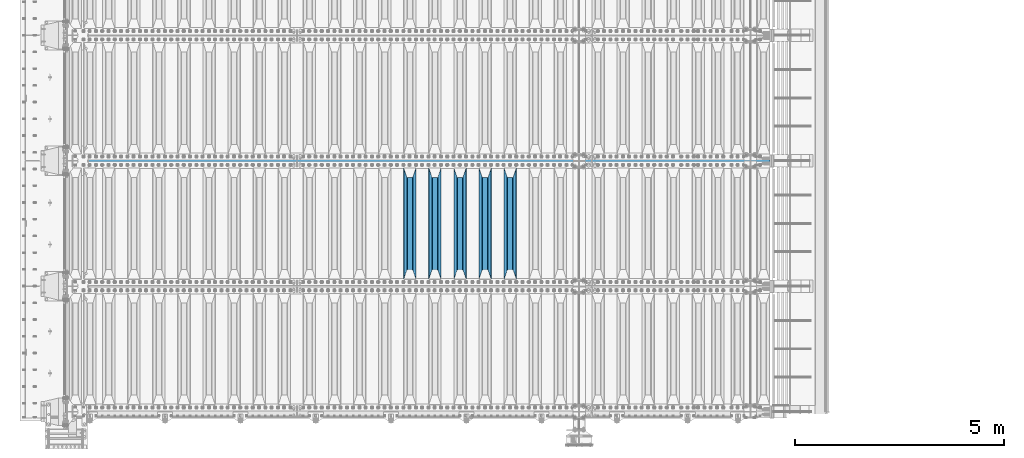
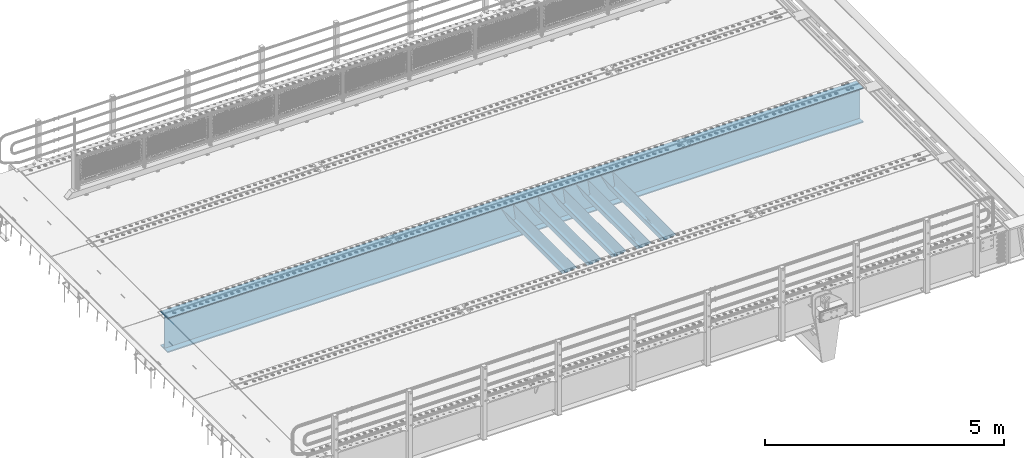
# One storey, part 111 of 257: 6 beams.
"""IFC2X3 building model written with IfcOpenShell, lengths in millimetres."""

from ifc_helpers import new_model, si_unit, frame, origin_with_axes, place, context, subcontext, project, spatial, faceted_brep, material, type_object, element, save


model = new_model("IFC2X3")

# Units and contexts
model_context = context("Model", 3, precision=1e-05, world=origin_with_axes())
body_context = subcontext(model_context, "Body", "Model", "MODEL_VIEW")
ifc_project = project(units=[si_unit("LENGTHUNIT", "METRE", prefix="MILLI"), si_unit("AREAUNIT", "SQUARE_METRE"), si_unit("VOLUMEUNIT", "CUBIC_METRE"), si_unit("MASSUNIT", "GRAM", prefix="KILO"), si_unit("TIMEUNIT", "SECOND"), si_unit("PLANEANGLEUNIT", "RADIAN"), si_unit("SOLIDANGLEUNIT", "STERADIAN"), si_unit("THERMODYNAMICTEMPERATUREUNIT", "DEGREE_CELSIUS"), si_unit("LUMINOUSINTENSITYUNIT", "LUMEN")], contexts=[model_context])

# Site, building, storey
site_placement = place(None, origin_with_axes())
site = spatial("IfcSite", under=ifc_project, at=site_placement, CompositionType="ELEMENT")
building_placement = place(site_placement, origin_with_axes())
building = spatial("IfcBuilding", under=site, at=building_placement, Name="Standard", CompositionType="ELEMENT")
storey_placement = place(building_placement, origin_with_axes())
storey = spatial("IfcBuildingStorey", under=building, at=storey_placement, Name="Undefined", CompositionType="ELEMENT", Elevation=0.0)

# Beams
ifc_material = material(Name="STEEL/S355N")
beam_type_1 = type_object("IfcBeamType", PredefinedType="NOTDEFINED")
beam_1_placement = place(storey_placement, frame((53050.0, 3175.0, -115.0), z_axis=(0.0, 0.0, 1.0), x_axis=(0.0, 1.0, 0.0)))
element("IfcBeam", 1, at=beam_1_placement, inside=storey, type_object=beam_type_1, material=ifc_material, context=body_context, shape_type="Brep", body=[
    faceted_brep([(0.0, 150.0, 115.0), (0.0, 143.690000000002, 115.0), (2650.00000000297, 143.690000000002, 115.0), (2650.00000000297, 150.0, 115.0), (2650.00000000297, 142.059565218406, 110.0000000031), (2650.00000000297, 148.369565218403, 110.0000000031), (2441.90079219208, -80.1103600731149, -98.0992078077845), (2437.7588105432, -77.5672621345584, -102.241189456673), (2434.06523489746, -74.4080125315522, -105.934765102404), (2430.91086095089, -70.7102721255724, -109.089139048974), (2428.37322971128, -66.5649389910031, -111.626770288588), (2426.51472138055, -62.0739139532889, -113.485278619323), (2425.38102192091, -57.3475956567636, -114.618978078955), (2424.99999999987, -52.5021667386536, -115.0), (2424.99999999987, 52.5021667386536, -115.0), (2425.38102192091, 57.3475956567636, -114.618978078955), (2426.51472138055, 62.0739139532889, -113.485278619323), (2428.37322971128, 66.5649389910031, -111.626770288588), (2430.91086095089, 70.7102721255724, -109.089139048974), (2434.06523489746, 74.4080125315522, -105.934765102404), (2437.7588105432, 77.5672621345584, -102.241189456673), (2441.90079219208, 80.1103600731149, -98.0992078077846), (2446.38936140511, 81.9747917625791, -93.6106385947584), (2448.24948500409, 76.2713538057287, -91.7505149957729), (2444.62967112262, 74.76777986261, -95.3703288772456), (2441.28936334126, 72.7168944282894, -98.710636658607), (2438.31067330438, 70.1691124903809, -101.689326695487), (2435.76682334747, 67.1870637758839, -104.233176652398), (2433.72034654133, 63.8440531834931, -106.279653458539), (2432.22154950041, 60.2222587982324, -107.778450499454), (2431.30727574265, 56.4107117849126, -108.692724257221), (2430.99999999987, 52.5031078186876, -109.0), (2430.99999999987, -52.5031078186876, -109.0), (2431.30727574265, -56.4107117849126, -108.692724257221), (2432.22154950041, -60.2222587982324, -107.778450499454), (2433.72034654133, -63.8440531834931, -106.279653458539), (2435.76682334747, -67.1870637758839, -104.233176652398), (2438.31067330438, -70.1691124903809, -101.689326695487), (2441.28936334126, -72.7168944282894, -98.7106366586071), (2444.62967112262, -74.76777986261, -95.3703288772457), (2448.24948500409, -76.2713538057287, -91.7505149957729), (2650.00000000297, -142.059565218406, 110.0000000031), (2650.00000000297, -148.369565218403, 110.0000000031), (2446.38936140511, -81.9747917625791, -93.6106385947584), (2650.00000000297, -143.690000000002, 115.0), (2650.00000000297, -150.0, 115.0), (0.0, -143.690000000002, 115.0), (0.0, -150.0, 115.0), (0.0, -148.369565218258, 110.000000002662), (203.61063859742, -81.9747917625791, -93.6106385947584), (208.099207810447, -80.1103600731149, -98.0992078077845), (212.241189459335, -77.5672621345584, -102.241189456673), (215.934765105066, -74.4080125315522, -105.934765102404), (219.089139051636, -70.7102721255724, -109.089139048974), (221.626770291251, -66.5649389910031, -111.626770288588), (223.485278621985, -62.0739139532889, -113.485278619323), (224.618978081617, -57.3475956567636, -114.618978078955), (225.000000002662, -52.5021667386536, -115.0), (225.000000002662, 52.5021667386536, -115.0), (224.618978081617, 57.3475956567636, -114.618978078955), (223.485278621985, 62.0739139532889, -113.485278619323), (221.626770291251, 66.5649389910031, -111.626770288588), (219.089139051636, 70.7102721255724, -109.089139048974), (215.934765105066, 74.4080125315522, -105.934765102404), (212.241189459335, 77.5672621345584, -102.241189456673), (208.099207810447, 80.1103600731149, -98.0992078077846), (203.61063859742, 81.9747917625791, -93.6106385947584), (0.0, 148.369565218258, 110.000000002662), (0.0, 142.05956521826, 110.000000002662), (201.750514998435, 76.2713538057287, -91.7505149957729), (205.370328879908, 74.76777986261, -95.3703288772456), (208.710636661269, 72.7168944282894, -98.710636658607), (211.689326698149, 70.1691124903809, -101.689326695487), (214.233176655061, 67.1870637758839, -104.233176652398), (216.279653461201, 63.8440531834931, -106.279653458539), (217.778450502116, 60.2222587982324, -107.778450499454), (218.692724259884, 56.4107117849126, -108.692724257221), (219.000000002662, 52.5031078186876, -109.0), (219.000000002662, -52.5031078186876, -109.0), (218.692724259884, -56.4107117849126, -108.692724257221), (217.778450502116, -60.2222587982324, -107.778450499454), (216.279653461201, -63.8440531834931, -106.279653458539), (214.233176655061, -67.1870637758839, -104.233176652398), (211.689326698149, -70.1691124903809, -101.689326695487), (208.710636661269, -72.7168944282894, -98.7106366586071), (205.370328879908, -74.76777986261, -95.3703288772457), (201.750514998435, -76.2713538057287, -91.7505149957729), (0.0, -142.05956521826, 110.000000002662)], [[[0, 1, 2, 3]], [[3, 2, 4, 5]], [[6, 7, 8, 9, 10, 11, 12, 13, 14, 15, 16, 17, 18, 19, 20, 21, 22, 5, 4, 23, 24, 25, 26, 27, 28, 29, 30, 31, 32, 33, 34, 35, 36, 37, 38, 39, 40, 41, 42, 43]], [[44, 45, 42, 41]], [[46, 47, 45, 44]], [[43, 42, 45, 47, 48, 49]], [[6, 43, 49, 50]], [[7, 6, 50, 51]], [[8, 7, 51, 52]], [[9, 8, 52, 53]], [[10, 9, 53, 54]], [[11, 10, 54, 55]], [[12, 11, 55, 56]], [[13, 12, 56, 57]], [[14, 13, 57, 58]], [[15, 14, 58, 59]], [[16, 15, 59, 60]], [[17, 16, 60, 61]], [[18, 17, 61, 62]], [[19, 18, 62, 63]], [[20, 19, 63, 64]], [[21, 20, 64, 65]], [[22, 21, 65, 66]], [[0, 3, 5, 22, 66, 67]], [[1, 0, 67, 68]], [[23, 4, 2, 1, 68, 69]], [[24, 23, 69, 70]], [[25, 24, 70, 71]], [[26, 25, 71, 72]], [[27, 26, 72, 73]], [[28, 27, 73, 74]], [[29, 28, 74, 75]], [[30, 29, 75, 76]], [[31, 30, 76, 77]], [[32, 31, 77, 78]], [[33, 32, 78, 79]], [[34, 33, 79, 80]], [[35, 34, 80, 81]], [[36, 35, 81, 82]], [[37, 36, 82, 83]], [[38, 37, 83, 84]], [[39, 38, 84, 85]], [[40, 39, 85, 86]], [[46, 44, 41, 40, 86, 87]], [[47, 46, 87, 48]], [[86, 85, 84, 83, 82, 81, 80, 79, 78, 77, 76, 75, 74, 73, 72, 71, 70, 69, 68, 67, 66, 65, 64, 63, 62, 61, 60, 59, 58, 57, 56, 55, 54, 53, 52, 51, 50, 49, 48, 87]]]),
])
beam_2_placement = place(storey_placement, frame((52450.0, 3175.0, -115.0), z_axis=(0.0, 0.0, 1.0), x_axis=(0.0, 1.0, 0.0)))
element("IfcBeam", 2, at=beam_2_placement, inside=storey, type_object=beam_type_1, material=ifc_material, context=body_context, shape_type="Brep", body=[
    faceted_brep([(0.0, 150.0, 115.0), (0.0, 143.690000000002, 115.0), (2650.00000000297, 143.690000000002, 115.0), (2650.00000000297, 150.0, 115.0), (2650.00000000297, 142.059565218406, 110.0000000031), (2650.00000000297, 148.369565218403, 110.0000000031), (2441.90079219208, -80.1103600731149, -98.0992078077845), (2437.7588105432, -77.5672621345584, -102.241189456673), (2434.06523489746, -74.4080125315522, -105.934765102404), (2430.91086095089, -70.7102721255724, -109.089139048974), (2428.37322971128, -66.5649389910031, -111.626770288588), (2426.51472138055, -62.0739139532889, -113.485278619323), (2425.38102192091, -57.3475956567636, -114.618978078955), (2424.99999999987, -52.5021667386536, -115.0), (2424.99999999987, 52.5021667386536, -115.0), (2425.38102192091, 57.3475956567636, -114.618978078955), (2426.51472138055, 62.0739139532889, -113.485278619323), (2428.37322971128, 66.5649389910031, -111.626770288588), (2430.91086095089, 70.7102721255724, -109.089139048974), (2434.06523489746, 74.4080125315522, -105.934765102404), (2437.7588105432, 77.5672621345584, -102.241189456673), (2441.90079219208, 80.1103600731149, -98.0992078077846), (2446.38936140511, 81.9747917625791, -93.6106385947584), (2448.24948500409, 76.2713538057287, -91.7505149957729), (2444.62967112262, 74.76777986261, -95.3703288772456), (2441.28936334126, 72.7168944282894, -98.710636658607), (2438.31067330438, 70.1691124903809, -101.689326695487), (2435.76682334747, 67.1870637758839, -104.233176652398), (2433.72034654133, 63.8440531834931, -106.279653458539), (2432.22154950041, 60.2222587982324, -107.778450499454), (2431.30727574265, 56.4107117849126, -108.692724257221), (2430.99999999987, 52.5031078186876, -109.0), (2430.99999999987, -52.5031078186876, -109.0), (2431.30727574265, -56.4107117849126, -108.692724257221), (2432.22154950041, -60.2222587982324, -107.778450499454), (2433.72034654133, -63.8440531834931, -106.279653458539), (2435.76682334747, -67.1870637758839, -104.233176652398), (2438.31067330438, -70.1691124903809, -101.689326695487), (2441.28936334126, -72.7168944282894, -98.7106366586071), (2444.62967112262, -74.76777986261, -95.3703288772457), (2448.24948500409, -76.2713538057287, -91.7505149957729), (2650.00000000297, -142.059565218406, 110.0000000031), (2650.00000000297, -148.369565218403, 110.0000000031), (2446.38936140511, -81.9747917625791, -93.6106385947584), (2650.00000000297, -143.690000000002, 115.0), (2650.00000000297, -150.0, 115.0), (0.0, -143.690000000002, 115.0), (0.0, -150.0, 115.0), (0.0, -148.369565218258, 110.000000002662), (203.61063859742, -81.9747917625791, -93.6106385947584), (208.099207810447, -80.1103600731149, -98.0992078077845), (212.241189459335, -77.5672621345584, -102.241189456673), (215.934765105066, -74.4080125315522, -105.934765102404), (219.089139051636, -70.7102721255724, -109.089139048974), (221.626770291251, -66.5649389910031, -111.626770288588), (223.485278621985, -62.0739139532889, -113.485278619323), (224.618978081617, -57.3475956567636, -114.618978078955), (225.000000002662, -52.5021667386536, -115.0), (225.000000002662, 52.5021667386536, -115.0), (224.618978081617, 57.3475956567636, -114.618978078955), (223.485278621985, 62.0739139532889, -113.485278619323), (221.626770291251, 66.5649389910031, -111.626770288588), (219.089139051636, 70.7102721255724, -109.089139048974), (215.934765105066, 74.4080125315522, -105.934765102404), (212.241189459335, 77.5672621345584, -102.241189456673), (208.099207810447, 80.1103600731149, -98.0992078077846), (203.61063859742, 81.9747917625791, -93.6106385947584), (0.0, 148.369565218258, 110.000000002662), (0.0, 142.05956521826, 110.000000002662), (201.750514998435, 76.2713538057287, -91.7505149957729), (205.370328879908, 74.76777986261, -95.3703288772456), (208.710636661269, 72.7168944282894, -98.710636658607), (211.689326698149, 70.1691124903809, -101.689326695487), (214.233176655061, 67.1870637758839, -104.233176652398), (216.279653461201, 63.8440531834931, -106.279653458539), (217.778450502116, 60.2222587982324, -107.778450499454), (218.692724259884, 56.4107117849126, -108.692724257221), (219.000000002662, 52.5031078186876, -109.0), (219.000000002662, -52.5031078186876, -109.0), (218.692724259884, -56.4107117849126, -108.692724257221), (217.778450502116, -60.2222587982324, -107.778450499454), (216.279653461201, -63.8440531834931, -106.279653458539), (214.233176655061, -67.1870637758839, -104.233176652398), (211.689326698149, -70.1691124903809, -101.689326695487), (208.710636661269, -72.7168944282894, -98.7106366586071), (205.370328879908, -74.76777986261, -95.3703288772457), (201.750514998435, -76.2713538057287, -91.7505149957729), (0.0, -142.05956521826, 110.000000002662)], [[[0, 1, 2, 3]], [[3, 2, 4, 5]], [[6, 7, 8, 9, 10, 11, 12, 13, 14, 15, 16, 17, 18, 19, 20, 21, 22, 5, 4, 23, 24, 25, 26, 27, 28, 29, 30, 31, 32, 33, 34, 35, 36, 37, 38, 39, 40, 41, 42, 43]], [[44, 45, 42, 41]], [[46, 47, 45, 44]], [[43, 42, 45, 47, 48, 49]], [[6, 43, 49, 50]], [[7, 6, 50, 51]], [[8, 7, 51, 52]], [[9, 8, 52, 53]], [[10, 9, 53, 54]], [[11, 10, 54, 55]], [[12, 11, 55, 56]], [[13, 12, 56, 57]], [[14, 13, 57, 58]], [[15, 14, 58, 59]], [[16, 15, 59, 60]], [[17, 16, 60, 61]], [[18, 17, 61, 62]], [[19, 18, 62, 63]], [[20, 19, 63, 64]], [[21, 20, 64, 65]], [[22, 21, 65, 66]], [[0, 3, 5, 22, 66, 67]], [[1, 0, 67, 68]], [[23, 4, 2, 1, 68, 69]], [[24, 23, 69, 70]], [[25, 24, 70, 71]], [[26, 25, 71, 72]], [[27, 26, 72, 73]], [[28, 27, 73, 74]], [[29, 28, 74, 75]], [[30, 29, 75, 76]], [[31, 30, 76, 77]], [[32, 31, 77, 78]], [[33, 32, 78, 79]], [[34, 33, 79, 80]], [[35, 34, 80, 81]], [[36, 35, 81, 82]], [[37, 36, 82, 83]], [[38, 37, 83, 84]], [[39, 38, 84, 85]], [[40, 39, 85, 86]], [[46, 44, 41, 40, 86, 87]], [[47, 46, 87, 48]], [[86, 85, 84, 83, 82, 81, 80, 79, 78, 77, 76, 75, 74, 73, 72, 71, 70, 69, 68, 67, 66, 65, 64, 63, 62, 61, 60, 59, 58, 57, 56, 55, 54, 53, 52, 51, 50, 49, 48, 87]]]),
])
beam_3_placement = place(storey_placement, frame((51850.0, 3175.0, -115.0), z_axis=(0.0, 0.0, 1.0), x_axis=(0.0, 1.0, 0.0)))
element("IfcBeam", 3, at=beam_3_placement, inside=storey, type_object=beam_type_1, material=ifc_material, context=body_context, shape_type="Brep", body=[
    faceted_brep([(0.0, 150.0, 115.0), (0.0, 143.690000000002, 115.0), (2650.00000000297, 143.690000000002, 115.0), (2650.00000000297, 150.0, 115.0), (2650.00000000297, 142.059565218406, 110.0000000031), (2650.00000000297, 148.369565218403, 110.0000000031), (2441.90079219208, -80.1103600731149, -98.0992078077845), (2437.7588105432, -77.5672621345584, -102.241189456673), (2434.06523489746, -74.4080125315522, -105.934765102404), (2430.91086095089, -70.7102721255724, -109.089139048974), (2428.37322971128, -66.5649389910031, -111.626770288588), (2426.51472138055, -62.0739139532889, -113.485278619323), (2425.38102192091, -57.3475956567636, -114.618978078955), (2424.99999999987, -52.5021667386536, -115.0), (2424.99999999987, 52.5021667386536, -115.0), (2425.38102192091, 57.3475956567636, -114.618978078955), (2426.51472138055, 62.0739139532889, -113.485278619323), (2428.37322971128, 66.5649389910031, -111.626770288588), (2430.91086095089, 70.7102721255724, -109.089139048974), (2434.06523489746, 74.4080125315522, -105.934765102404), (2437.7588105432, 77.5672621345584, -102.241189456673), (2441.90079219208, 80.1103600731149, -98.0992078077846), (2446.38936140511, 81.9747917625791, -93.6106385947584), (2448.24948500409, 76.2713538057287, -91.7505149957729), (2444.62967112262, 74.76777986261, -95.3703288772456), (2441.28936334126, 72.7168944282894, -98.710636658607), (2438.31067330438, 70.1691124903809, -101.689326695487), (2435.76682334747, 67.1870637758839, -104.233176652398), (2433.72034654133, 63.8440531834931, -106.279653458539), (2432.22154950041, 60.2222587982324, -107.778450499454), (2431.30727574265, 56.4107117849126, -108.692724257221), (2430.99999999987, 52.5031078186876, -109.0), (2430.99999999987, -52.5031078186876, -109.0), (2431.30727574265, -56.4107117849126, -108.692724257221), (2432.22154950041, -60.2222587982324, -107.778450499454), (2433.72034654133, -63.8440531834931, -106.279653458539), (2435.76682334747, -67.1870637758839, -104.233176652398), (2438.31067330438, -70.1691124903809, -101.689326695487), (2441.28936334126, -72.7168944282894, -98.7106366586071), (2444.62967112262, -74.76777986261, -95.3703288772457), (2448.24948500409, -76.2713538057287, -91.7505149957729), (2650.00000000297, -142.059565218406, 110.0000000031), (2650.00000000297, -148.369565218403, 110.0000000031), (2446.38936140511, -81.9747917625791, -93.6106385947584), (2650.00000000297, -143.690000000002, 115.0), (2650.00000000297, -150.0, 115.0), (0.0, -143.690000000002, 115.0), (0.0, -150.0, 115.0), (0.0, -148.369565218258, 110.000000002662), (203.61063859742, -81.9747917625791, -93.6106385947584), (208.099207810447, -80.1103600731149, -98.0992078077845), (212.241189459335, -77.5672621345584, -102.241189456673), (215.934765105066, -74.4080125315522, -105.934765102404), (219.089139051636, -70.7102721255724, -109.089139048974), (221.626770291251, -66.5649389910031, -111.626770288588), (223.485278621985, -62.0739139532889, -113.485278619323), (224.618978081617, -57.3475956567636, -114.618978078955), (225.000000002662, -52.5021667386536, -115.0), (225.000000002662, 52.5021667386536, -115.0), (224.618978081617, 57.3475956567636, -114.618978078955), (223.485278621985, 62.0739139532889, -113.485278619323), (221.626770291251, 66.5649389910031, -111.626770288588), (219.089139051636, 70.7102721255724, -109.089139048974), (215.934765105066, 74.4080125315522, -105.934765102404), (212.241189459335, 77.5672621345584, -102.241189456673), (208.099207810447, 80.1103600731149, -98.0992078077846), (203.61063859742, 81.9747917625791, -93.6106385947584), (0.0, 148.369565218258, 110.000000002662), (0.0, 142.05956521826, 110.000000002662), (201.750514998435, 76.2713538057287, -91.7505149957729), (205.370328879908, 74.76777986261, -95.3703288772456), (208.710636661269, 72.7168944282894, -98.710636658607), (211.689326698149, 70.1691124903809, -101.689326695487), (214.233176655061, 67.1870637758839, -104.233176652398), (216.279653461201, 63.8440531834931, -106.279653458539), (217.778450502116, 60.2222587982324, -107.778450499454), (218.692724259884, 56.4107117849126, -108.692724257221), (219.000000002662, 52.5031078186876, -109.0), (219.000000002662, -52.5031078186876, -109.0), (218.692724259884, -56.4107117849126, -108.692724257221), (217.778450502116, -60.2222587982324, -107.778450499454), (216.279653461201, -63.8440531834931, -106.279653458539), (214.233176655061, -67.1870637758839, -104.233176652398), (211.689326698149, -70.1691124903809, -101.689326695487), (208.710636661269, -72.7168944282894, -98.7106366586071), (205.370328879908, -74.76777986261, -95.3703288772457), (201.750514998435, -76.2713538057287, -91.7505149957729), (0.0, -142.05956521826, 110.000000002662)], [[[0, 1, 2, 3]], [[3, 2, 4, 5]], [[6, 7, 8, 9, 10, 11, 12, 13, 14, 15, 16, 17, 18, 19, 20, 21, 22, 5, 4, 23, 24, 25, 26, 27, 28, 29, 30, 31, 32, 33, 34, 35, 36, 37, 38, 39, 40, 41, 42, 43]], [[44, 45, 42, 41]], [[46, 47, 45, 44]], [[43, 42, 45, 47, 48, 49]], [[6, 43, 49, 50]], [[7, 6, 50, 51]], [[8, 7, 51, 52]], [[9, 8, 52, 53]], [[10, 9, 53, 54]], [[11, 10, 54, 55]], [[12, 11, 55, 56]], [[13, 12, 56, 57]], [[14, 13, 57, 58]], [[15, 14, 58, 59]], [[16, 15, 59, 60]], [[17, 16, 60, 61]], [[18, 17, 61, 62]], [[19, 18, 62, 63]], [[20, 19, 63, 64]], [[21, 20, 64, 65]], [[22, 21, 65, 66]], [[0, 3, 5, 22, 66, 67]], [[1, 0, 67, 68]], [[23, 4, 2, 1, 68, 69]], [[24, 23, 69, 70]], [[25, 24, 70, 71]], [[26, 25, 71, 72]], [[27, 26, 72, 73]], [[28, 27, 73, 74]], [[29, 28, 74, 75]], [[30, 29, 75, 76]], [[31, 30, 76, 77]], [[32, 31, 77, 78]], [[33, 32, 78, 79]], [[34, 33, 79, 80]], [[35, 34, 80, 81]], [[36, 35, 81, 82]], [[37, 36, 82, 83]], [[38, 37, 83, 84]], [[39, 38, 84, 85]], [[40, 39, 85, 86]], [[46, 44, 41, 40, 86, 87]], [[47, 46, 87, 48]], [[86, 85, 84, 83, 82, 81, 80, 79, 78, 77, 76, 75, 74, 73, 72, 71, 70, 69, 68, 67, 66, 65, 64, 63, 62, 61, 60, 59, 58, 57, 56, 55, 54, 53, 52, 51, 50, 49, 48, 87]]]),
])
beam_4_placement = place(storey_placement, frame((51250.0, 3175.0, -115.0), z_axis=(0.0, 0.0, 1.0), x_axis=(0.0, 1.0, 0.0)))
element("IfcBeam", 4, at=beam_4_placement, inside=storey, type_object=beam_type_1, material=ifc_material, context=body_context, shape_type="Brep", body=[
    faceted_brep([(0.0, 150.0, 115.0), (0.0, 143.690000000002, 115.0), (2650.00000000297, 143.690000000002, 115.0), (2650.00000000297, 150.0, 115.0), (2650.00000000297, 142.059565218406, 110.0000000031), (2650.00000000297, 148.369565218403, 110.0000000031), (2441.90079219208, -80.1103600731149, -98.0992078077845), (2437.7588105432, -77.5672621345584, -102.241189456673), (2434.06523489746, -74.4080125315522, -105.934765102404), (2430.91086095089, -70.7102721255724, -109.089139048974), (2428.37322971128, -66.5649389910031, -111.626770288588), (2426.51472138055, -62.0739139532889, -113.485278619323), (2425.38102192091, -57.3475956567636, -114.618978078955), (2424.99999999987, -52.5021667386536, -115.0), (2424.99999999987, 52.5021667386536, -115.0), (2425.38102192091, 57.3475956567636, -114.618978078955), (2426.51472138055, 62.0739139532889, -113.485278619323), (2428.37322971128, 66.5649389910031, -111.626770288588), (2430.91086095089, 70.7102721255724, -109.089139048974), (2434.06523489746, 74.4080125315522, -105.934765102404), (2437.7588105432, 77.5672621345584, -102.241189456673), (2441.90079219208, 80.1103600731149, -98.0992078077846), (2446.38936140511, 81.9747917625791, -93.6106385947584), (2448.24948500409, 76.2713538057287, -91.7505149957729), (2444.62967112262, 74.76777986261, -95.3703288772456), (2441.28936334126, 72.7168944282894, -98.710636658607), (2438.31067330438, 70.1691124903809, -101.689326695487), (2435.76682334747, 67.1870637758839, -104.233176652398), (2433.72034654133, 63.8440531834931, -106.279653458539), (2432.22154950041, 60.2222587982324, -107.778450499454), (2431.30727574265, 56.4107117849126, -108.692724257221), (2430.99999999987, 52.5031078186876, -109.0), (2430.99999999987, -52.5031078186876, -109.0), (2431.30727574265, -56.4107117849126, -108.692724257221), (2432.22154950041, -60.2222587982324, -107.778450499454), (2433.72034654133, -63.8440531834931, -106.279653458539), (2435.76682334747, -67.1870637758839, -104.233176652398), (2438.31067330438, -70.1691124903809, -101.689326695487), (2441.28936334126, -72.7168944282894, -98.7106366586071), (2444.62967112262, -74.76777986261, -95.3703288772457), (2448.24948500409, -76.2713538057287, -91.7505149957729), (2650.00000000297, -142.059565218406, 110.0000000031), (2650.00000000297, -148.369565218403, 110.0000000031), (2446.38936140511, -81.9747917625791, -93.6106385947584), (2650.00000000297, -143.690000000002, 115.0), (2650.00000000297, -150.0, 115.0), (0.0, -143.690000000002, 115.0), (0.0, -150.0, 115.0), (0.0, -148.369565218258, 110.000000002662), (203.61063859742, -81.9747917625791, -93.6106385947584), (208.099207810447, -80.1103600731149, -98.0992078077845), (212.241189459335, -77.5672621345584, -102.241189456673), (215.934765105066, -74.4080125315522, -105.934765102404), (219.089139051636, -70.7102721255724, -109.089139048974), (221.626770291251, -66.5649389910031, -111.626770288588), (223.485278621985, -62.0739139532889, -113.485278619323), (224.618978081617, -57.3475956567636, -114.618978078955), (225.000000002662, -52.5021667386536, -115.0), (225.000000002662, 52.5021667386536, -115.0), (224.618978081617, 57.3475956567636, -114.618978078955), (223.485278621985, 62.0739139532889, -113.485278619323), (221.626770291251, 66.5649389910031, -111.626770288588), (219.089139051636, 70.7102721255724, -109.089139048974), (215.934765105066, 74.4080125315522, -105.934765102404), (212.241189459335, 77.5672621345584, -102.241189456673), (208.099207810447, 80.1103600731149, -98.0992078077846), (203.61063859742, 81.9747917625791, -93.6106385947584), (0.0, 148.369565218258, 110.000000002662), (0.0, 142.05956521826, 110.000000002662), (201.750514998435, 76.2713538057287, -91.7505149957729), (205.370328879908, 74.76777986261, -95.3703288772456), (208.710636661269, 72.7168944282894, -98.710636658607), (211.689326698149, 70.1691124903809, -101.689326695487), (214.233176655061, 67.1870637758839, -104.233176652398), (216.279653461201, 63.8440531834931, -106.279653458539), (217.778450502116, 60.2222587982324, -107.778450499454), (218.692724259884, 56.4107117849126, -108.692724257221), (219.000000002662, 52.5031078186876, -109.0), (219.000000002662, -52.5031078186876, -109.0), (218.692724259884, -56.4107117849126, -108.692724257221), (217.778450502116, -60.2222587982324, -107.778450499454), (216.279653461201, -63.8440531834931, -106.279653458539), (214.233176655061, -67.1870637758839, -104.233176652398), (211.689326698149, -70.1691124903809, -101.689326695487), (208.710636661269, -72.7168944282894, -98.7106366586071), (205.370328879908, -74.76777986261, -95.3703288772457), (201.750514998435, -76.2713538057287, -91.7505149957729), (0.0, -142.05956521826, 110.000000002662)], [[[0, 1, 2, 3]], [[3, 2, 4, 5]], [[6, 7, 8, 9, 10, 11, 12, 13, 14, 15, 16, 17, 18, 19, 20, 21, 22, 5, 4, 23, 24, 25, 26, 27, 28, 29, 30, 31, 32, 33, 34, 35, 36, 37, 38, 39, 40, 41, 42, 43]], [[44, 45, 42, 41]], [[46, 47, 45, 44]], [[43, 42, 45, 47, 48, 49]], [[6, 43, 49, 50]], [[7, 6, 50, 51]], [[8, 7, 51, 52]], [[9, 8, 52, 53]], [[10, 9, 53, 54]], [[11, 10, 54, 55]], [[12, 11, 55, 56]], [[13, 12, 56, 57]], [[14, 13, 57, 58]], [[15, 14, 58, 59]], [[16, 15, 59, 60]], [[17, 16, 60, 61]], [[18, 17, 61, 62]], [[19, 18, 62, 63]], [[20, 19, 63, 64]], [[21, 20, 64, 65]], [[22, 21, 65, 66]], [[0, 3, 5, 22, 66, 67]], [[1, 0, 67, 68]], [[23, 4, 2, 1, 68, 69]], [[24, 23, 69, 70]], [[25, 24, 70, 71]], [[26, 25, 71, 72]], [[27, 26, 72, 73]], [[28, 27, 73, 74]], [[29, 28, 74, 75]], [[30, 29, 75, 76]], [[31, 30, 76, 77]], [[32, 31, 77, 78]], [[33, 32, 78, 79]], [[34, 33, 79, 80]], [[35, 34, 80, 81]], [[36, 35, 81, 82]], [[37, 36, 82, 83]], [[38, 37, 83, 84]], [[39, 38, 84, 85]], [[40, 39, 85, 86]], [[46, 44, 41, 40, 86, 87]], [[47, 46, 87, 48]], [[86, 85, 84, 83, 82, 81, 80, 79, 78, 77, 76, 75, 74, 73, 72, 71, 70, 69, 68, 67, 66, 65, 64, 63, 62, 61, 60, 59, 58, 57, 56, 55, 54, 53, 52, 51, 50, 49, 48, 87]]]),
])
beam_5_placement = place(storey_placement, frame((50650.0, 3175.0, -115.0), z_axis=(0.0, 0.0, 1.0), x_axis=(0.0, 1.0, 0.0)))
element("IfcBeam", 5, at=beam_5_placement, inside=storey, type_object=beam_type_1, material=ifc_material, context=body_context, shape_type="Brep", body=[
    faceted_brep([(0.0, 150.0, 115.0), (0.0, 143.690000000002, 115.0), (2650.00000000297, 143.690000000002, 115.0), (2650.00000000297, 150.0, 115.0), (2650.00000000297, 142.059565218406, 110.0000000031), (2650.00000000297, 148.369565218403, 110.0000000031), (2441.90079219208, -80.1103600731149, -98.0992078077845), (2437.7588105432, -77.5672621345584, -102.241189456673), (2434.06523489746, -74.4080125315522, -105.934765102404), (2430.91086095089, -70.7102721255724, -109.089139048974), (2428.37322971128, -66.5649389910031, -111.626770288588), (2426.51472138055, -62.0739139532889, -113.485278619323), (2425.38102192091, -57.3475956567636, -114.618978078955), (2424.99999999987, -52.5021667386536, -115.0), (2424.99999999987, 52.5021667386536, -115.0), (2425.38102192091, 57.3475956567636, -114.618978078955), (2426.51472138055, 62.0739139532889, -113.485278619323), (2428.37322971128, 66.5649389910031, -111.626770288588), (2430.91086095089, 70.7102721255724, -109.089139048974), (2434.06523489746, 74.4080125315522, -105.934765102404), (2437.7588105432, 77.5672621345584, -102.241189456673), (2441.90079219208, 80.1103600731149, -98.0992078077846), (2446.38936140511, 81.9747917625791, -93.6106385947584), (2448.24948500409, 76.2713538057287, -91.7505149957729), (2444.62967112262, 74.76777986261, -95.3703288772456), (2441.28936334126, 72.7168944282894, -98.710636658607), (2438.31067330438, 70.1691124903809, -101.689326695487), (2435.76682334747, 67.1870637758839, -104.233176652398), (2433.72034654133, 63.8440531834931, -106.279653458539), (2432.22154950041, 60.2222587982324, -107.778450499454), (2431.30727574265, 56.4107117849126, -108.692724257221), (2430.99999999987, 52.5031078186876, -109.0), (2430.99999999987, -52.5031078186876, -109.0), (2431.30727574265, -56.4107117849126, -108.692724257221), (2432.22154950041, -60.2222587982324, -107.778450499454), (2433.72034654133, -63.8440531834931, -106.279653458539), (2435.76682334747, -67.1870637758839, -104.233176652398), (2438.31067330438, -70.1691124903809, -101.689326695487), (2441.28936334126, -72.7168944282894, -98.7106366586071), (2444.62967112262, -74.76777986261, -95.3703288772457), (2448.24948500409, -76.2713538057287, -91.7505149957729), (2650.00000000297, -142.059565218406, 110.0000000031), (2650.00000000297, -148.369565218403, 110.0000000031), (2446.38936140511, -81.9747917625791, -93.6106385947584), (2650.00000000297, -143.690000000002, 115.0), (2650.00000000297, -150.0, 115.0), (0.0, -143.690000000002, 115.0), (0.0, -150.0, 115.0), (0.0, -148.369565218258, 110.000000002662), (203.61063859742, -81.9747917625791, -93.6106385947584), (208.099207810447, -80.1103600731149, -98.0992078077845), (212.241189459335, -77.5672621345584, -102.241189456673), (215.934765105066, -74.4080125315522, -105.934765102404), (219.089139051636, -70.7102721255724, -109.089139048974), (221.626770291251, -66.5649389910031, -111.626770288588), (223.485278621985, -62.0739139532889, -113.485278619323), (224.618978081617, -57.3475956567636, -114.618978078955), (225.000000002662, -52.5021667386536, -115.0), (225.000000002662, 52.5021667386536, -115.0), (224.618978081617, 57.3475956567636, -114.618978078955), (223.485278621985, 62.0739139532889, -113.485278619323), (221.626770291251, 66.5649389910031, -111.626770288588), (219.089139051636, 70.7102721255724, -109.089139048974), (215.934765105066, 74.4080125315522, -105.934765102404), (212.241189459335, 77.5672621345584, -102.241189456673), (208.099207810447, 80.1103600731149, -98.0992078077846), (203.61063859742, 81.9747917625791, -93.6106385947584), (0.0, 148.369565218258, 110.000000002662), (0.0, 142.05956521826, 110.000000002662), (201.750514998435, 76.2713538057287, -91.7505149957729), (205.370328879908, 74.76777986261, -95.3703288772456), (208.710636661269, 72.7168944282894, -98.710636658607), (211.689326698149, 70.1691124903809, -101.689326695487), (214.233176655061, 67.1870637758839, -104.233176652398), (216.279653461201, 63.8440531834931, -106.279653458539), (217.778450502116, 60.2222587982324, -107.778450499454), (218.692724259884, 56.4107117849126, -108.692724257221), (219.000000002662, 52.5031078186876, -109.0), (219.000000002662, -52.5031078186876, -109.0), (218.692724259884, -56.4107117849126, -108.692724257221), (217.778450502116, -60.2222587982324, -107.778450499454), (216.279653461201, -63.8440531834931, -106.279653458539), (214.233176655061, -67.1870637758839, -104.233176652398), (211.689326698149, -70.1691124903809, -101.689326695487), (208.710636661269, -72.7168944282894, -98.7106366586071), (205.370328879908, -74.76777986261, -95.3703288772457), (201.750514998435, -76.2713538057287, -91.7505149957729), (0.0, -142.05956521826, 110.000000002662)], [[[0, 1, 2, 3]], [[3, 2, 4, 5]], [[6, 7, 8, 9, 10, 11, 12, 13, 14, 15, 16, 17, 18, 19, 20, 21, 22, 5, 4, 23, 24, 25, 26, 27, 28, 29, 30, 31, 32, 33, 34, 35, 36, 37, 38, 39, 40, 41, 42, 43]], [[44, 45, 42, 41]], [[46, 47, 45, 44]], [[43, 42, 45, 47, 48, 49]], [[6, 43, 49, 50]], [[7, 6, 50, 51]], [[8, 7, 51, 52]], [[9, 8, 52, 53]], [[10, 9, 53, 54]], [[11, 10, 54, 55]], [[12, 11, 55, 56]], [[13, 12, 56, 57]], [[14, 13, 57, 58]], [[15, 14, 58, 59]], [[16, 15, 59, 60]], [[17, 16, 60, 61]], [[18, 17, 61, 62]], [[19, 18, 62, 63]], [[20, 19, 63, 64]], [[21, 20, 64, 65]], [[22, 21, 65, 66]], [[0, 3, 5, 22, 66, 67]], [[1, 0, 67, 68]], [[23, 4, 2, 1, 68, 69]], [[24, 23, 69, 70]], [[25, 24, 70, 71]], [[26, 25, 71, 72]], [[27, 26, 72, 73]], [[28, 27, 73, 74]], [[29, 28, 74, 75]], [[30, 29, 75, 76]], [[31, 30, 76, 77]], [[32, 31, 77, 78]], [[33, 32, 78, 79]], [[34, 33, 79, 80]], [[35, 34, 80, 81]], [[36, 35, 81, 82]], [[37, 36, 82, 83]], [[38, 37, 83, 84]], [[39, 38, 84, 85]], [[40, 39, 85, 86]], [[46, 44, 41, 40, 86, 87]], [[47, 46, 87, 48]], [[86, 85, 84, 83, 82, 81, 80, 79, 78, 77, 76, 75, 74, 73, 72, 71, 70, 69, 68, 67, 66, 65, 64, 63, 62, 61, 60, 59, 58, 57, 56, 55, 54, 53, 52, 51, 50, 49, 48, 87]]]),
])
beam_type_2 = type_object("IfcBeamType", Name="HEA900", PredefinedType="NOTDEFINED")
beam_6_placement = place(storey_placement, frame((42460.0, 6000.0, -445.0), z_axis=(0.0, 0.0, 1.0), x_axis=(1.0, 0.0, 0.0)))
element("IfcBeam", 6, at=beam_6_placement, inside=storey, type_object=beam_type_2, material=ifc_material, ObjectType="HEA900", context=body_context, shape_type="Brep", body=[
    faceted_brep([(0.0, 150.0, -445.0), (0.0, 150.0, -415.0), (16807.0, 150.0, -415.0), (16807.0, 150.0, -445.0), (0.0, 8.0, -415.0), (16807.0, 8.0, -415.0), (0.0, 8.0, 415.0), (16807.0, 8.0, 415.0), (0.0, 150.0, 415.0), (16807.0, 150.0, 415.0), (0.0, 150.0, 445.0), (16807.0, 150.0, 445.0), (0.0, -150.0, 445.0), (16807.0, -150.0, 445.0), (0.0, -150.0, 415.0), (16807.0, -150.0, 415.0), (0.0, -8.0, 415.0), (16807.0, -8.0, 415.0), (0.0, -8.0, -415.0), (16807.0, -8.0, -415.0), (0.0, -150.0, -415.0), (16807.0, -150.0, -415.0), (0.0, -150.0, -445.0), (16807.0, -150.0, -445.0)], [[[0, 1, 2, 3]], [[1, 4, 5, 2]], [[4, 6, 7, 5]], [[6, 8, 9, 7]], [[8, 10, 11, 9]], [[10, 12, 13, 11]], [[12, 14, 15, 13]], [[14, 16, 17, 15]], [[16, 18, 19, 17]], [[18, 20, 21, 19]], [[20, 22, 23, 21]], [[22, 0, 3, 23]], [[5, 7, 9, 11, 13, 15, 17, 19, 21, 23, 3, 2]], [[22, 20, 18, 16, 14, 12, 10, 8, 6, 4, 1, 0]]]),
])

save(model, "model.ifc")
